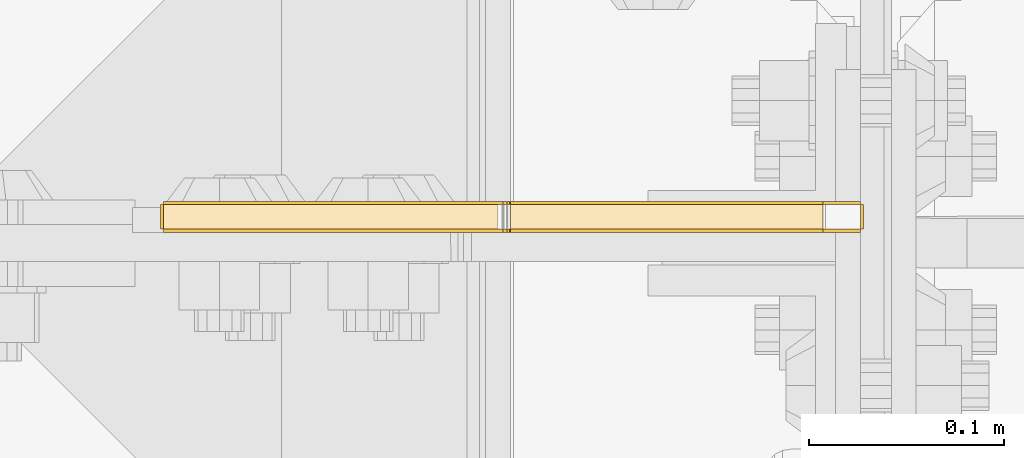
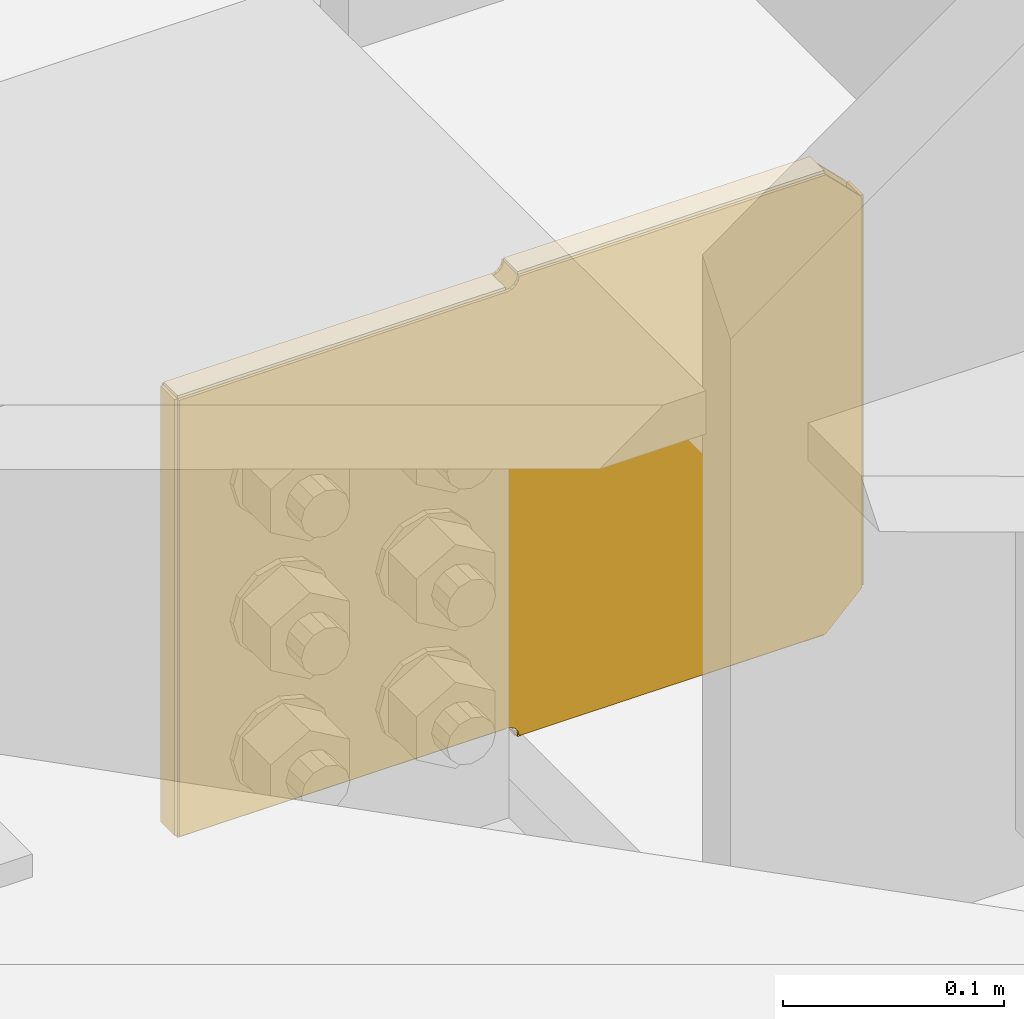
# One storey, part 3840 of 3843: 8 coverings.
"""IFC2X3 building model written with IfcOpenShell, lengths in millimetres."""

from ifc_helpers import new_model, si_unit, frame, origin_with_axes, place, context, subcontext, project, spatial, faceted_brep, material, element, save


model = new_model("IFC2X3")

# Units and contexts
model_context = context("Model", 3, precision=1e-05, world=origin_with_axes())
body_context = subcontext(model_context, "Body", "Model", "MODEL_VIEW")
ifc_project = project(units=[si_unit("LENGTHUNIT", "METRE", prefix="MILLI"), si_unit("AREAUNIT", "SQUARE_METRE"), si_unit("VOLUMEUNIT", "CUBIC_METRE"), si_unit("MASSUNIT", "GRAM", prefix="KILO"), si_unit("TIMEUNIT", "SECOND"), si_unit("PLANEANGLEUNIT", "RADIAN"), si_unit("SOLIDANGLEUNIT", "STERADIAN"), si_unit("THERMODYNAMICTEMPERATUREUNIT", "DEGREE_CELSIUS"), si_unit("LUMINOUSINTENSITYUNIT", "LUMEN")], contexts=[model_context])

# Site, building, storey
site_placement = place(None, origin_with_axes())
site = spatial("IfcSite", under=ifc_project, at=site_placement, CompositionType="ELEMENT")
building_placement = place(site_placement, origin_with_axes())
building = spatial("IfcBuilding", under=site, at=building_placement, Name="Undefined", CompositionType="ELEMENT")
storey_placement = place(building_placement, origin_with_axes())
storey = spatial("IfcBuildingStorey", under=building, at=storey_placement, Name="Undefined", CompositionType="ELEMENT", Elevation=0.0)

# Coverings
ifc_material = material(Name="Undefined/Undefined")
covering_1_placement = place(storey_placement, frame((85641.656, 33865.3437500954, 42162.1964901587), z_axis=(0.0, -1.0, 0.0), x_axis=(0.0, 0.0, 1.0)))
element("IfcCovering", 1, at=covering_1_placement, inside=storey, material=ifc_material, Name="SurfaceTreatment", PredefinedType="NOTDEFINED", context=body_context, shape_type="Brep", body=[
    faceted_brep([(0.0, -0.793499999999767, 12.7000000000116), (215.900042926245, -0.793499999999767, 12.7000000000116), (215.900042926245, 0.793499999999767, 12.7000000000116), (0.0, 0.793499999999767, 12.7000000000116), (215.900042926245, -0.793499999999767, 0.0), (215.900042926245, 0.793499999999767, 0.0), (-1.45519152283669e-11, -0.793499999999767, 0.0), (-1.45519152283669e-11, 0.793499999999767, 0.0)], [[[0, 1, 2, 3]], [[1, 4, 5, 2]], [[4, 6, 7, 5]], [[6, 0, 3, 7]], [[5, 7, 3, 2]], [[6, 4, 1, 0]]]),
])
covering_2_placement = place(storey_placement, frame((85621.8124999986, 33865.3437500954, 42397.9400330846), z_axis=(0.0, -1.0, 0.0), x_axis=(-1.0, 0.0, 0.0)))
element("IfcCovering", 2, at=covering_2_placement, inside=storey, material=ifc_material, Name="SurfaceTreatment", PredefinedType="NOTDEFINED", context=body_context, shape_type="Brep", body=[
    faceted_brep([(0.0, -0.793499999999767, 12.7000000000116), (160.337500002235, -0.79350000051636, 12.7000000000116), (160.337500002235, 0.793499999483174, 12.7000000000116), (0.0, 0.793499999999767, 12.7000000000116), (160.337500002235, -0.79350000051636, 0.0), (160.337500002235, 0.793499999483174, 0.0), (-1.45519152283669e-11, -0.793499999999767, 0.0), (-1.45519152283669e-11, 0.793499999999767, 0.0)], [[[0, 1, 2, 3]], [[1, 4, 5, 2]], [[4, 6, 7, 5]], [[6, 0, 3, 7]], [[5, 7, 3, 2]], [[6, 4, 1, 0]]]),
])
covering_3_placement = place(storey_placement, frame((85455.1035176249, 33865.3437500954, 42391.5685505375), z_axis=(0.0, -1.0, 0.0), x_axis=(-1.0, 0.0, 0.0)))
element("IfcCovering", 3, at=covering_3_placement, inside=storey, material=ifc_material, Name="SurfaceTreatment", PredefinedType="NOTDEFINED", context=body_context, shape_type="Brep", body=[
    faceted_brep([(0.0, -0.793499999999767, 12.7000000000116), (171.428517630484, -0.793499999999767, 12.7000000000116), (171.428517630484, 0.793499999999767, 12.7000000000116), (0.0, 0.793499999999767, 12.7000000000116), (171.428517630484, -0.793499999999767, 0.0), (171.428517630484, 0.793499999999767, 0.0), (-1.45519152283669e-11, -0.793499999999767, 0.0), (-1.45519152283669e-11, 0.793499999999767, 0.0)], [[[0, 1, 2, 3]], [[1, 4, 5, 2]], [[4, 6, 7, 5]], [[6, 0, 3, 7]], [[5, 7, 3, 2]], [[6, 4, 1, 0]]]),
])
covering_4_placement = place(storey_placement, frame((85282.8814999944, 33865.3437500954, 42390.775050492), z_axis=(0.0, -1.0, 0.0), x_axis=(0.0, 0.0, -1.0)))
element("IfcCovering", 4, at=covering_4_placement, inside=storey, material=ifc_material, Name="SurfaceTreatment", PredefinedType="NOTDEFINED", context=body_context, shape_type="Brep", body=[
    faceted_brep([(0.0, -0.793499999999767, 12.7000000000116), (241.299999998839, -0.793499999999767, 12.7000000000116), (241.299999998839, 0.793499999999767, 12.7000000000116), (0.0, 0.793499999999767, 12.7000000000116), (241.299999998839, -0.793499999999767, 0.0), (241.299999998839, 0.793499999999767, 0.0), (-1.45519152283669e-11, -0.793499999999767, 0.0), (-1.45519152283669e-11, 0.793499999999767, 0.0)], [[[0, 1, 2, 3]], [[1, 4, 5, 2]], [[4, 6, 7, 5]], [[6, 0, 3, 7]], [[5, 7, 3, 2]], [[6, 4, 1, 0]]]),
])
covering_5_placement = place(storey_placement, frame((85283.6749999944, 33865.3437500954, 42148.6815505448), z_axis=(0.0, -1.0, 0.0), x_axis=(1.0, 0.0, 0.0)))
element("IfcCovering", 5, at=covering_5_placement, inside=storey, material=ifc_material, Name="SurfaceTreatment", PredefinedType="NOTDEFINED", context=body_context, shape_type="Brep", body=[
    faceted_brep([(0.0, -0.793499999999767, 12.7000000000116), (171.471439650428, -0.793499999999767, 12.7000000000116), (171.471439650428, 0.793499999999767, 12.7000000000116), (0.0, 0.793499999999767, 12.7000000000116), (171.471439650428, -0.793499999999767, 0.0), (171.471439650428, 0.793499999999767, 0.0), (-1.45519152283669e-11, -0.793499999999767, 0.0), (-1.45519152283669e-11, 0.793499999999767, 0.0)], [[[0, 1, 2, 3]], [[1, 4, 5, 2]], [[4, 6, 7, 5]], [[6, 0, 3, 7]], [[5, 7, 3, 2]], [[6, 4, 1, 0]]]),
])
covering_6_placement = place(storey_placement, frame((85461.4749999972, 33865.3437500954, 42142.352990164), z_axis=(0.0, -1.0, 0.0), x_axis=(1.0, 0.0, 0.0)))
element("IfcCovering", 6, at=covering_6_placement, inside=storey, material=ifc_material, Name="SurfaceTreatment", PredefinedType="NOTDEFINED", context=body_context, shape_type="Brep", body=[
    faceted_brep([(0.0, -0.793499999999767, 12.7000000000116), (160.337500002235, -0.79350000051636, 12.7000000000116), (160.337500002235, 0.793499999483174, 12.7000000000116), (0.0, 0.793499999999767, 12.7000000000116), (160.337500002235, -0.79350000051636, 0.0), (160.337500002235, 0.793499999483174, 0.0), (-1.45519152283669e-11, -0.793499999999767, 0.0), (-1.45519152283669e-11, 0.793499999999767, 0.0)], [[[0, 1, 2, 3]], [[1, 4, 5, 2]], [[4, 6, 7, 5]], [[6, 0, 3, 7]], [[5, 7, 3, 2]], [[6, 4, 1, 0]]]),
])
covering_7_placement = place(storey_placement, frame((85621.8124999997, 33851.8502500954, 42397.1465330849), z_axis=(0.0, 0.0, -1.0), x_axis=(-1.0, 0.0, 0.0)))
element("IfcCovering", 7, at=covering_7_placement, inside=storey, material=ifc_material, Name="SurfaceTreatment", PredefinedType="NOTDEFINED", context=body_context, shape_type="Brep", body=[
    faceted_brep([(-19.0499999814492, -0.793499999999767, 19.0500000190223), (-19.0499997679872, -0.793499999999767, 234.950042945267), (-19.0499997679872, 0.793499999999767, 234.950042945267), (-19.0499999814492, 0.793499999999767, 19.0500000190223), (2.51151504926383e-07, -0.793499999999767, 254.000042926054), (2.51151504926383e-07, 0.793499999999767, 254.000042926054), (160.337500253678, -0.793499999999767, 254.000042765198), (160.337500253678, 0.793499999999767, 254.000042765198), (160.819233223825, -0.793499999999767, 251.578207585124), (160.819233223825, 0.793499999999767, 251.578207585124), (162.191092661305, -0.793499999999767, 249.525074841025), (162.191092661305, 0.793499999999767, 249.525074841025), (164.244225402683, -0.793499999999767, 248.15321539947), (164.244225402683, 0.793499999999767, 248.15321539947), (166.666060599789, -0.793499999999767, 247.671482424492), (166.666060599789, 0.793499999999767, 247.671482424492), (338.137500250217, -0.793499999999767, 247.671482252466), (338.137500250217, 0.793499999999767, 247.671482252466), (338.137500011653, -0.793499999999767, 6.37148225362762), (338.137500011653, 0.793499999999767, 6.37148225362762), (166.708982381169, -0.793499999999767, 6.37148242560943), (166.708982381169, 0.793499999999767, 6.37148242560943), (164.270721637193, -0.793499999999767, 5.88648221128824), (164.270721637193, 0.793499999999767, 5.88648221128824), (162.203663987631, -0.793499999999767, 4.50531844951183), (162.203663987631, 0.793499999999767, 4.50531844951183), (160.822500221722, -0.793499999999767, 2.43826080272993), (160.822500221722, 0.793499999999767, 2.43826080272993), (160.337500002235, -0.79350000051636, 0.0), (160.337500002235, 0.793499999483174, 0.0), (-1.45519152283669e-11, -0.793499999999767, 0.0), (-1.45519152283669e-11, 0.793499999999767, 0.0)], [[[0, 1, 2, 3]], [[1, 4, 5, 2]], [[4, 6, 7, 5]], [[6, 8, 9, 7]], [[8, 10, 11, 9]], [[10, 12, 13, 11]], [[12, 14, 15, 13]], [[14, 16, 17, 15]], [[16, 18, 19, 17]], [[18, 20, 21, 19]], [[20, 22, 23, 21]], [[22, 24, 25, 23]], [[24, 26, 27, 25]], [[26, 28, 29, 27]], [[28, 30, 31, 29]], [[30, 0, 3, 31]], [[5, 7, 9, 11, 13, 15, 17, 19, 21, 23, 25, 27, 29, 31, 3, 2]], [[30, 28, 26, 24, 22, 20, 18, 16, 14, 12, 10, 8, 6, 4, 1, 0]]]),
])
covering_8_placement = place(storey_placement, frame((85621.8124999997, 33866.1372500954, 42143.1464901588), z_axis=(0.0, 0.0, 1.0), x_axis=(-1.0, 0.0, 0.0)))
element("IfcCovering", 8, at=covering_8_placement, inside=storey, material=ifc_material, Name="SurfaceTreatment", PredefinedType="NOTDEFINED", context=body_context, shape_type="Brep", body=[
    faceted_brep([(-19.0499999814492, -0.793499999999767, 19.0500000190223), (-19.0499997679872, -0.793499999999767, 234.950042945267), (-19.0499997679872, 0.793499999999767, 234.950042945267), (-19.0499999814492, 0.793499999999767, 19.0500000190223), (2.51151504926383e-07, -0.793499999999767, 254.000042926054), (2.51151504926383e-07, 0.793499999999767, 254.000042926054), (160.337500253678, -0.793499999999767, 254.000042765198), (160.337500253678, 0.793499999999767, 254.000042765198), (160.822500219307, -0.793499999999767, 251.56178196198), (160.822500219307, 0.793499999999767, 251.56178196198), (162.203663983179, -0.793499999999767, 249.494724313816), (162.203663983179, 0.793499999999767, 249.494724313816), (164.270721631357, -0.793499999999767, 248.113560549966), (164.270721631357, 0.793499999999767, 248.113560549966), (166.708982374854, -0.793499999999767, 247.628560333193), (166.708982374854, 0.793499999999767, 247.628560333193), (338.137500005338, -0.793499999999767, 247.628560333193), (338.137500005338, 0.793499999999767, 247.628560333193), (338.137500005338, -0.793499999999767, 6.32856033435382), (338.137500005338, 0.793499999999767, 6.32856033435382), (166.66606035491, -0.793499999999767, 6.32856033435382), (166.66606035491, 0.793499999999767, 6.32856033435382), (164.244225157337, -0.793499999999767, 5.84682736180548), (164.244225157337, 0.793499999999767, 5.84682736180548), (162.191092414592, -0.793499999999767, 4.47496792230959), (162.191092414592, 0.793499999999767, 4.47496792230959), (160.819232975089, -0.793499999999767, 2.42183517959347), (160.819232975089, 0.793499999999767, 2.42183517959347), (160.337500002235, -0.79350000051636, 0.0), (160.337500002235, 0.793499999483174, 0.0), (-1.45519152283669e-11, -0.793499999999767, 0.0), (-1.45519152283669e-11, 0.793499999999767, 0.0)], [[[0, 1, 2, 3]], [[1, 4, 5, 2]], [[4, 6, 7, 5]], [[6, 8, 9, 7]], [[8, 10, 11, 9]], [[10, 12, 13, 11]], [[12, 14, 15, 13]], [[14, 16, 17, 15]], [[16, 18, 19, 17]], [[18, 20, 21, 19]], [[20, 22, 23, 21]], [[22, 24, 25, 23]], [[24, 26, 27, 25]], [[26, 28, 29, 27]], [[28, 30, 31, 29]], [[30, 0, 3, 31]], [[5, 7, 9, 11, 13, 15, 17, 19, 21, 23, 25, 27, 29, 31, 3, 2]], [[30, 28, 26, 24, 22, 20, 18, 16, 14, 12, 10, 8, 6, 4, 1, 0]]]),
])

save(model, "model.ifc")
